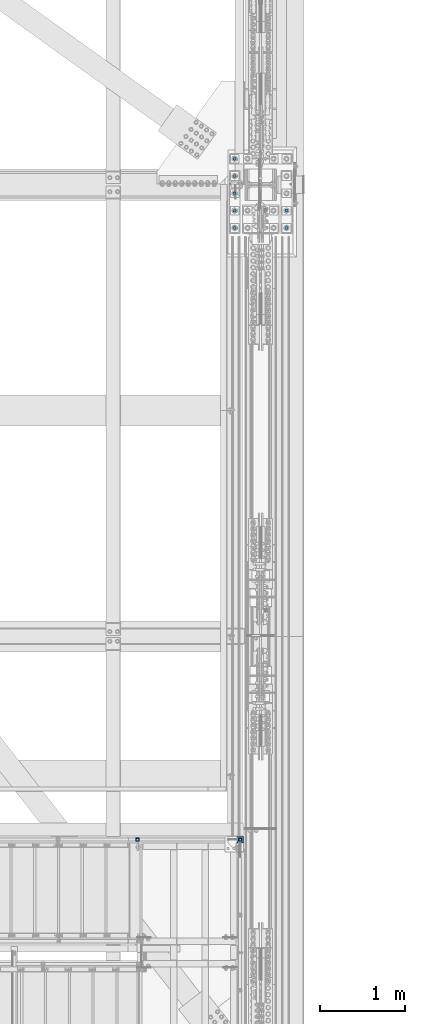
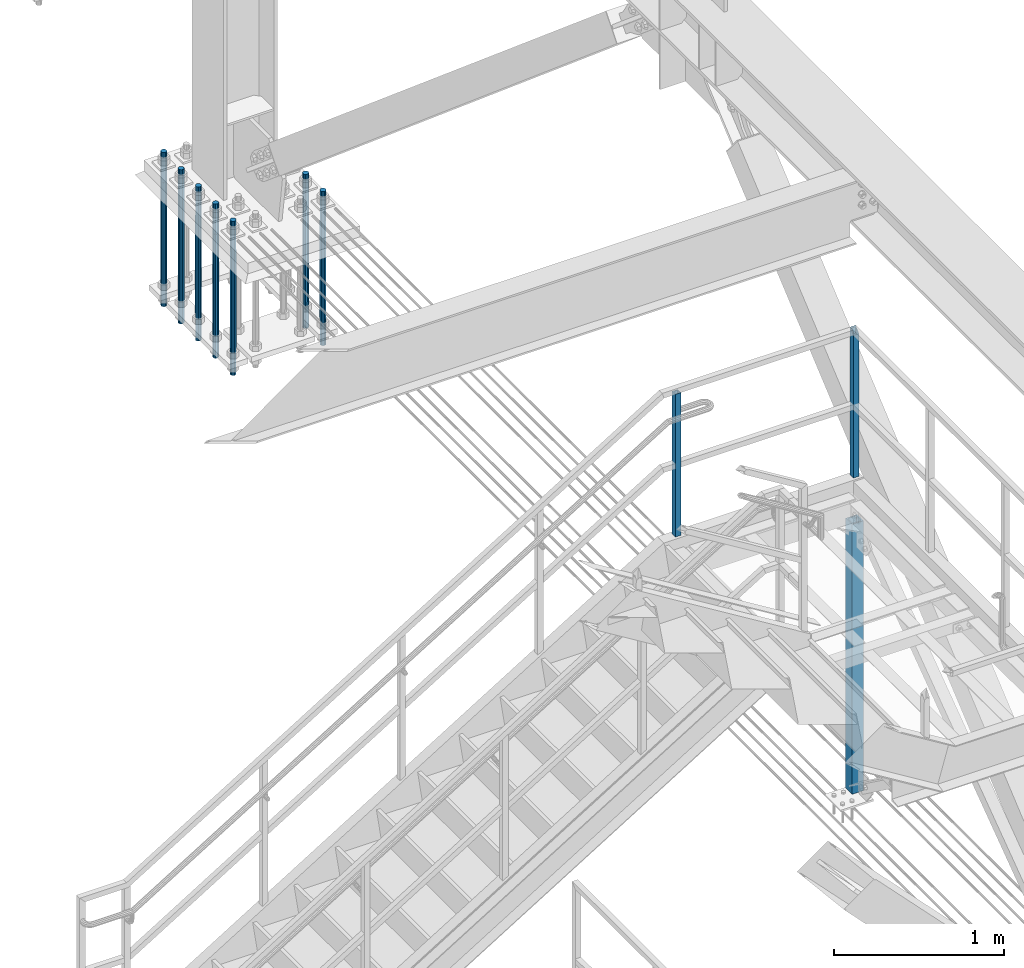
# One storey, part 1412 of 3843: 10 columns, 4 elements without a shape of their own.
"""IFC2X3 building model written with IfcOpenShell, lengths in millimetres."""

from ifc_helpers import new_model, si_unit, frame, origin_with_axes, place, context, subcontext, project, spatial, faceted_brep, material, type_object, element, aggregate, save


model = new_model("IFC2X3")

# Units and contexts
model_context = context("Model", 3, precision=1e-05, world=origin_with_axes())
body_context = subcontext(model_context, "Body", "Model", "MODEL_VIEW")
ifc_project = project(units=[si_unit("LENGTHUNIT", "METRE", prefix="MILLI"), si_unit("AREAUNIT", "SQUARE_METRE"), si_unit("VOLUMEUNIT", "CUBIC_METRE"), si_unit("MASSUNIT", "GRAM", prefix="KILO"), si_unit("TIMEUNIT", "SECOND"), si_unit("PLANEANGLEUNIT", "RADIAN"), si_unit("SOLIDANGLEUNIT", "STERADIAN"), si_unit("THERMODYNAMICTEMPERATUREUNIT", "DEGREE_CELSIUS"), si_unit("LUMINOUSINTENSITYUNIT", "LUMEN")], contexts=[model_context])

# Site, building, storey
site_placement = place(None, origin_with_axes())
site = spatial("IfcSite", under=ifc_project, at=site_placement, CompositionType="ELEMENT")
building_placement = place(site_placement, origin_with_axes())
building = spatial("IfcBuilding", under=site, at=building_placement, Name="Undefined", CompositionType="ELEMENT")
storey_placement = place(building_placement, origin_with_axes())
storey = spatial("IfcBuildingStorey", under=building, at=storey_placement, Name="Undefined", CompositionType="ELEMENT", Elevation=0.0)

# Assembly, column
assembly_1_placement = place(storey_placement, origin_with_axes())
assembly_1 = element("IfcElementAssembly", 1, at=assembly_1_placement, inside=storey, Name="RAIL", AssemblyPlace="NOTDEFINED", PredefinedType="RIGID_FRAME")
ifc_material_1 = material()
column_type_1 = type_object("IfcColumnType", Name="HSS1-1/2X1-1/2X1/4", PredefinedType="NOTDEFINED")
column_1_placement = place(assembly_1_placement, frame((84200.9999999997, 17919.7, 32715.1999999846), z_axis=(-1.0, 0.0, 0.0), x_axis=(0.0, 0.0, 1.0)))
column_1 = element("IfcColumn", 2, at=column_1_placement, type_object=column_type_1, material=ifc_material_1, Name="POST", ObjectType="HSS1-1/2X1-1/2X1/4", context=body_context, shape_type="Brep", body=[
    faceted_brep([(1047.75000076629, -19.0499992350015, 19.0499992349942), (1047.75000076629, 19.0499992350015, 19.0499992349942), (25.4000000135893, 19.0499992350015, 19.0499992349942), (25.4000000135893, -19.0499992350015, 19.0499992349942), (1047.750000765, -19.0499992350015, -19.0499992350015), (25.4000000135893, -19.0499992350015, -19.0499992349942), (1047.750000765, 19.0499992350015, -19.0499992350015), (25.4000000135893, 19.0499992350015, -19.0499992349942), (1047.75000076497, -12.6999993300014, 12.6999993299978), (1047.75000076497, 12.6999993300014, 12.6999993299978), (1047.75000076497, 12.6999993300014, -12.6999993299978), (1047.75000076497, -12.6999993300014, -12.6999993299978), (25.4000000135893, -12.6999993300014, 12.6999993299978), (25.4000000135893, 12.6999993300014, 12.6999993299978), (25.4000000135893, 12.6999993300014, -12.6999993299978), (25.4000000135893, -12.6999993300014, -12.6999993299978)], [[[0, 1, 2, 3]], [[4, 0, 3, 5]], [[6, 4, 5, 7]], [[1, 6, 7, 2]], [[0, 4, 6, 1], [8, 9, 10, 11]], [[9, 8, 12, 13]], [[10, 9, 13, 14]], [[11, 10, 14, 15]], [[8, 11, 15, 12]], [[7, 5, 3, 2], [14, 13, 12, 15]]]),
])
aggregate(assembly_1, [column_1])

assembly_2_placement = place(storey_placement, origin_with_axes())
assembly_2 = element("IfcElementAssembly", 3, at=assembly_2_placement, inside=storey, Name="RAIL", AssemblyPlace="NOTDEFINED", PredefinedType="RIGID_FRAME")
column_2_placement = place(assembly_2_placement, frame((85407.4999999662, 17919.7, 32740.599999999), z_axis=(-1.0, 0.0, 0.0), x_axis=(0.0, 0.0, 1.0)))
column_2 = element("IfcColumn", 4, at=column_2_placement, type_object=column_type_1, material=ifc_material_1, Name="POST", ObjectType="HSS1-1/2X1-1/2X1/4", context=body_context, shape_type="Brep", body=[
    faceted_brep([(0.0, 12.6999993299978, -12.6999993300014), (0.0, -12.6999993299978, -12.6999993300014), (1028.70000067009, -12.6999993300014, -12.6999993299978), (1054.10000067001, 12.6999993300014, -12.6999993299978), (0.0, -12.6999993299978, 12.6999993300014), (1028.70000067002, -12.6999993299978, 12.6999993299978), (0.0, 12.6999993299978, 12.6999993300014), (1054.10000067129, 12.6999993300014, 12.6999993299978), (0.0, 19.0500000000029, -19.0499999999993), (0.0, 19.0499992350015, 19.0499992350015), (1060.44999923509, 19.0499992350015, 19.0499992349942), (1060.44999923502, 19.0499992350015, -19.0499992350015), (0.0, -19.0499992350015, 19.0499992350015), (1022.35000076501, -19.0499992350015, 19.0499992350015), (0.0, -19.0499992350015, -19.0499992350015), (1022.35000076501, -19.0499992350015, -19.0499992350015)], [[[0, 1, 2, 3]], [[1, 4, 5, 2]], [[4, 6, 7, 5]], [[6, 0, 3, 7]], [[8, 9, 10, 11]], [[9, 12, 13, 10]], [[12, 14, 15, 13]], [[14, 8, 11, 15]], [[13, 15, 11, 10], [5, 7, 3, 2]], [[14, 12, 9, 8], [6, 4, 1, 0]]]),
])
aggregate(assembly_2, [column_2])

assembly_3_placement = place(storey_placement, origin_with_axes())
assembly_3 = element("IfcElementAssembly", 5, at=assembly_3_placement, inside=storey, Name="POST", AssemblyPlace="NOTDEFINED", PredefinedType="RIGID_FRAME")
ifc_material_2 = material()
column_type_2 = type_object("IfcColumnType", Name="HSS3X3X3/8", PredefinedType="NOTDEFINED")
column_3_placement = place(assembly_3_placement, frame((85407.5000000298, 17919.6999998921, 30480.0000000001), z_axis=(-1.0, 0.0, 0.0), x_axis=(0.0, 0.0, 1.0)))
column_3 = element("IfcColumn", 6, at=column_3_placement, type_object=column_type_2, material=ifc_material_2, Name="POST", ObjectType="HSS3X3X3/8", context=body_context, shape_type="Brep", body=[
    faceted_brep([(12.7000000000007, 28.5749999999971, -28.5749999999971), (12.7000000000007, -28.5749999999971, -28.5749999999971), (1946.27499999952, -28.5750000000007, -28.5749999999971), (1946.27499999952, 28.5750000000007, -28.5749999999971), (12.7000000000007, -28.5749999999971, 28.5749999999971), (1946.27499999952, -28.5750000000007, 28.5749999999971), (12.7000000000007, 28.5749999999971, 28.5749999999971), (1946.27499999952, 28.5750000000007, 28.5749999999971), (12.7000000000007, 38.1000000000058, -38.0999999999985), (12.7000000000007, 38.1000000000058, 38.0999999999985), (1946.27499999952, 38.0999999999985, 38.1000000000058), (1946.27499999952, 38.0999999999985, -38.1000000000058), (12.7000000000007, -38.1000000000058, 38.0999999999985), (1946.27499999952, -38.0999999999985, 38.1000000000058), (12.7000000000007, -38.1000000000058, -38.0999999999985), (1946.27499999952, -38.0999999999985, -38.1000000000058)], [[[0, 1, 2, 3]], [[1, 4, 5, 2]], [[4, 6, 7, 5]], [[6, 0, 3, 7]], [[8, 9, 10, 11]], [[9, 12, 13, 10]], [[12, 14, 15, 13]], [[14, 8, 11, 15]], [[13, 15, 11, 10], [5, 7, 3, 2]], [[14, 12, 9, 8], [6, 4, 1, 0]]]),
])
aggregate(assembly_3, [column_3])

# Assembly, columns
assembly_4_placement = place(storey_placement, origin_with_axes())
assembly_4 = element("IfcElementAssembly", 7, at=assembly_4_placement, inside=storey, Name="TEMPLATE", AssemblyPlace="NOTDEFINED", PredefinedType="RIGID_FRAME")
ifc_material_3 = material(Name="Undefined/F1554-GR.55")
column_type_3 = type_object("IfcColumnType", PredefinedType="NOTDEFINED")
column_4_placement = place(assembly_4_placement, frame((85953.6, 25107.9, 30022.8), z_axis=(1.0, 0.0, 0.0), x_axis=(0.0, 0.0, -1.0)))
column_4 = element("IfcColumn", 8, at=column_4_placement, type_object=column_type_3, material=ifc_material_3, Name="ANCHOR_ROD", context=body_context, shape_type="Brep", body=[
    faceted_brep([(-215.899999999998, -16.0214699700118, 9.25), (-215.899999999998, -9.25, 16.0214699700155), (-215.899999999998, 0.0, 18.5), (-215.899999999998, 9.25, 16.0214699700155), (-215.899999999998, 16.0214699700118, 9.25), (-215.899999999998, 18.5, 0.0), (-215.899999999998, 16.0214699700118, -9.25), (-215.899999999998, 9.25, -16.0214699700155), (-215.899999999998, 0.0, -18.5), (-215.899999999998, -9.25, -16.0214699700155), (-215.899999999998, -16.0214699700118, -9.25), (-215.899999999998, -18.5, 0.0), (0.0, 18.5, 0.0), (0.0, 16.0214699700118, -9.25), (0.0, 9.25, -16.0214699700155), (0.0, 0.0, -18.5), (0.0, -9.25, -16.0214699700155), (0.0, -16.0214699700118, -9.25), (0.0, -18.5, 0.0), (0.0, -16.0214699700118, 9.25), (0.0, -9.25, 16.0214699700155), (0.0, 0.0, 18.5), (0.0, 9.25, 16.0214699700155), (0.0, 16.0214699700118, 9.25), (0.0, -16.4977839420972, 9.52500000000146), (0.0, -9.52500000000146, 16.4977839420972), (0.0, 0.0, 19.0499989999989), (0.0, 9.52500000000146, 16.4977839420972), (0.0, 16.4977839420972, 9.52500000000146), (0.0, 19.0500000000029, 0.0), (0.0, 16.4977839420972, -9.52500000000146), (0.0, 9.52500000000146, -16.4977839420972), (0.0, 0.0, -19.0499989999989), (0.0, -9.52500000000146, -16.4977839420972), (0.0, -16.4977839420972, -9.52500000000146), (0.0, -19.0500000000029, 0.0), (698.5, -19.0499999999993, 0.0), (698.5, -16.4977839420935, 9.52499999999418), (698.5, -9.52500000000146, 16.4977839420899), (698.5, 0.0, 19.0500000000029), (698.5, 9.52500000000146, 16.4977839420899), (698.5, 16.4977839420935, 9.52499999999418), (698.5, 19.0499999999993, 0.0), (698.5, 16.4977839420935, -9.52499999999418), (698.5, 9.52500000000146, -16.4977839420899), (698.5, 0.0, -19.0500000000029), (698.5, -9.52500000000146, -16.4977839420899), (698.5, -16.4977839420935, -9.52499999999418), (698.5, -9.25, 16.0214699700155), (698.5, 0.0, 18.5), (698.5, 9.25, 16.0214699700155), (698.5, 16.0214699700118, 9.25), (698.5, 18.5, 0.0), (698.5, 16.0214699700118, -9.25), (698.5, 9.25, -16.0214699700155), (698.5, 0.0, -18.5), (698.5, -9.25, -16.0214699700155), (698.5, -16.0214699700118, -9.25), (698.5, -18.5, 0.0), (698.5, -16.0214699700118, 9.25), (889.0, -9.25, -16.0214699700155), (889.0, 0.0, -18.5), (889.0, 9.25, -16.0214699700155), (889.0, 16.0214699700118, -9.25), (889.0, 18.5, 0.0), (889.0, 16.0214699700118, 9.25), (889.0, 9.25, 16.0214699700155), (889.0, 0.0, 18.5), (889.0, -9.25, 16.0214699700155), (889.0, -16.0214699700118, 9.25), (889.0, -18.5, 0.0), (889.0, -16.0214699700118, -9.25)], [[[0, 1, 2, 3, 4, 5, 6, 7, 8, 9, 10, 11]], [[6, 5, 12, 13]], [[7, 6, 13, 14]], [[8, 7, 14, 15]], [[9, 8, 15, 16]], [[10, 9, 16, 17]], [[11, 10, 17, 18]], [[0, 11, 18, 19]], [[1, 0, 19, 20]], [[2, 1, 20, 21]], [[3, 2, 21, 22]], [[4, 3, 22, 23]], [[5, 4, 23, 12]], [[24, 25, 26, 27, 28, 29, 30, 31, 32, 33, 34, 35], [22, 21, 20, 19, 18, 17, 16, 15, 14, 13, 12, 23]], [[24, 35, 36, 37]], [[25, 24, 37, 38]], [[26, 25, 38, 39]], [[27, 26, 39, 40]], [[28, 27, 40, 41]], [[29, 28, 41, 42]], [[30, 29, 42, 43]], [[31, 30, 43, 44]], [[32, 31, 44, 45]], [[33, 32, 45, 46]], [[34, 33, 46, 47]], [[35, 34, 47, 36]], [[46, 45, 44, 43, 42, 41, 40, 39, 38, 37, 36, 47], [48, 49, 50, 51, 52, 53, 54, 55, 56, 57, 58, 59]], [[60, 61, 62, 63, 64, 65, 66, 67, 68, 69, 70, 71]], [[68, 67, 49, 48]], [[69, 68, 48, 59]], [[70, 69, 59, 58]], [[71, 70, 58, 57]], [[60, 71, 57, 56]], [[61, 60, 56, 55]], [[62, 61, 55, 54]], [[63, 62, 54, 53]], [[64, 63, 53, 52]], [[65, 64, 52, 51]], [[66, 65, 51, 50]], [[67, 66, 50, 49]]]),
])
column_5_placement = place(assembly_4_placement, frame((85953.6, 25311.1, 30022.8), z_axis=(1.0, 0.0, 0.0), x_axis=(0.0, 0.0, -1.0)))
column_5 = element("IfcColumn", 9, at=column_5_placement, type_object=column_type_3, material=ifc_material_3, Name="ANCHOR_ROD", context=body_context, shape_type="Brep", body=[
    faceted_brep([(-215.899999999998, -16.0214699700118, 9.25), (-215.899999999998, -9.25, 16.0214699700155), (-215.899999999998, 0.0, 18.5), (-215.899999999998, 9.25, 16.0214699700155), (-215.899999999998, 16.0214699700118, 9.25), (-215.899999999998, 18.5, 0.0), (-215.899999999998, 16.0214699700118, -9.25), (-215.899999999998, 9.25, -16.0214699700155), (-215.899999999998, 0.0, -18.5), (-215.899999999998, -9.25, -16.0214699700155), (-215.899999999998, -16.0214699700118, -9.25), (-215.899999999998, -18.5, 0.0), (0.0, 18.5, 0.0), (0.0, 16.0214699700118, -9.25), (0.0, 9.25, -16.0214699700155), (0.0, 0.0, -18.5), (0.0, -9.25, -16.0214699700155), (0.0, -16.0214699700118, -9.25), (0.0, -18.5, 0.0), (0.0, -16.0214699700118, 9.25), (0.0, -9.25, 16.0214699700155), (0.0, 0.0, 18.5), (0.0, 9.25, 16.0214699700155), (0.0, 16.0214699700118, 9.25), (0.0, -16.4977839420972, 9.52500000000146), (0.0, -9.52500000000146, 16.4977839420972), (0.0, 0.0, 19.0499989999989), (0.0, 9.52500000000146, 16.4977839420972), (0.0, 16.4977839420972, 9.52500000000146), (0.0, 19.0500000000029, 0.0), (0.0, 16.4977839420972, -9.52500000000146), (0.0, 9.52500000000146, -16.4977839420972), (0.0, 0.0, -19.0499989999989), (0.0, -9.52500000000146, -16.4977839420972), (0.0, -16.4977839420972, -9.52500000000146), (0.0, -19.0500000000029, 0.0), (698.5, -19.0499999999993, 0.0), (698.5, -16.4977839420935, 9.52499999999418), (698.5, -9.52500000000146, 16.4977839420899), (698.5, 0.0, 19.0500000000029), (698.5, 9.52500000000146, 16.4977839420899), (698.5, 16.4977839420935, 9.52499999999418), (698.5, 19.0499999999993, 0.0), (698.5, 16.4977839420935, -9.52499999999418), (698.5, 9.52500000000146, -16.4977839420899), (698.5, 0.0, -19.0500000000029), (698.5, -9.52500000000146, -16.4977839420899), (698.5, -16.4977839420935, -9.52499999999418), (698.5, -9.25, 16.0214699700155), (698.5, 0.0, 18.5), (698.5, 9.25, 16.0214699700155), (698.5, 16.0214699700118, 9.25), (698.5, 18.5, 0.0), (698.5, 16.0214699700118, -9.25), (698.5, 9.25, -16.0214699700155), (698.5, 0.0, -18.5), (698.5, -9.25, -16.0214699700155), (698.5, -16.0214699700118, -9.25), (698.5, -18.5, 0.0), (698.5, -16.0214699700118, 9.25), (889.0, -9.25, -16.0214699700155), (889.0, 0.0, -18.5), (889.0, 9.25, -16.0214699700155), (889.0, 16.0214699700118, -9.25), (889.0, 18.5, 0.0), (889.0, 16.0214699700118, 9.25), (889.0, 9.25, 16.0214699700155), (889.0, 0.0, 18.5), (889.0, -9.25, 16.0214699700155), (889.0, -16.0214699700118, 9.25), (889.0, -18.5, 0.0), (889.0, -16.0214699700118, -9.25)], [[[0, 1, 2, 3, 4, 5, 6, 7, 8, 9, 10, 11]], [[6, 5, 12, 13]], [[7, 6, 13, 14]], [[8, 7, 14, 15]], [[9, 8, 15, 16]], [[10, 9, 16, 17]], [[11, 10, 17, 18]], [[0, 11, 18, 19]], [[1, 0, 19, 20]], [[2, 1, 20, 21]], [[3, 2, 21, 22]], [[4, 3, 22, 23]], [[5, 4, 23, 12]], [[24, 25, 26, 27, 28, 29, 30, 31, 32, 33, 34, 35], [22, 21, 20, 19, 18, 17, 16, 15, 14, 13, 12, 23]], [[24, 35, 36, 37]], [[25, 24, 37, 38]], [[26, 25, 38, 39]], [[27, 26, 39, 40]], [[28, 27, 40, 41]], [[29, 28, 41, 42]], [[30, 29, 42, 43]], [[31, 30, 43, 44]], [[32, 31, 44, 45]], [[33, 32, 45, 46]], [[34, 33, 46, 47]], [[35, 34, 47, 36]], [[46, 45, 44, 43, 42, 41, 40, 39, 38, 37, 36, 47], [48, 49, 50, 51, 52, 53, 54, 55, 56, 57, 58, 59]], [[60, 61, 62, 63, 64, 65, 66, 67, 68, 69, 70, 71]], [[68, 67, 49, 48]], [[69, 68, 48, 59]], [[70, 69, 59, 58]], [[71, 70, 58, 57]], [[60, 71, 57, 56]], [[61, 60, 56, 55]], [[62, 61, 55, 54]], [[63, 62, 54, 53]], [[64, 63, 53, 52]], [[65, 64, 52, 51]], [[66, 65, 51, 50]], [[67, 66, 50, 49]]]),
])
column_6_placement = place(assembly_4_placement, frame((85344.0, 25107.9, 30022.8), z_axis=(1.0, 0.0, 0.0), x_axis=(0.0, 0.0, -1.0)))
column_6 = element("IfcColumn", 10, at=column_6_placement, type_object=column_type_3, material=ifc_material_3, Name="ANCHOR_ROD", context=body_context, shape_type="Brep", body=[
    faceted_brep([(-215.899999999998, -16.0214699700118, 9.25), (-215.899999999998, -9.25, 16.0214699700155), (-215.899999999998, 0.0, 18.5), (-215.899999999998, 9.25, 16.0214699700155), (-215.899999999998, 16.0214699700118, 9.25), (-215.899999999998, 18.5, 0.0), (-215.899999999998, 16.0214699700118, -9.25), (-215.899999999998, 9.25, -16.0214699700155), (-215.899999999998, 0.0, -18.5), (-215.899999999998, -9.25, -16.0214699700155), (-215.899999999998, -16.0214699700118, -9.25), (-215.899999999998, -18.5, 0.0), (0.0, 18.5, 0.0), (0.0, 16.0214699700118, -9.25), (0.0, 9.25, -16.0214699700155), (0.0, 0.0, -18.5), (0.0, -9.25, -16.0214699700155), (0.0, -16.0214699700118, -9.25), (0.0, -18.5, 0.0), (0.0, -16.0214699700118, 9.25), (0.0, -9.25, 16.0214699700155), (0.0, 0.0, 18.5), (0.0, 9.25, 16.0214699700155), (0.0, 16.0214699700118, 9.25), (0.0, -16.4977839420972, 9.52500000000146), (0.0, -9.52500000000146, 16.4977839420972), (0.0, 0.0, 19.0499989999989), (0.0, 9.52500000000146, 16.4977839420972), (0.0, 16.4977839420972, 9.52500000000146), (0.0, 19.0500000000029, 0.0), (0.0, 16.4977839420972, -9.52500000000146), (0.0, 9.52500000000146, -16.4977839420972), (0.0, 0.0, -19.0499989999989), (0.0, -9.52500000000146, -16.4977839420972), (0.0, -16.4977839420972, -9.52500000000146), (0.0, -19.0500000000029, 0.0), (698.5, -19.0499999999993, 0.0), (698.5, -16.4977839420935, 9.52499999999418), (698.5, -9.52500000000146, 16.4977839420899), (698.5, 0.0, 19.0500000000029), (698.5, 9.52500000000146, 16.4977839420899), (698.5, 16.4977839420935, 9.52499999999418), (698.5, 19.0499999999993, 0.0), (698.5, 16.4977839420935, -9.52499999999418), (698.5, 9.52500000000146, -16.4977839420899), (698.5, 0.0, -19.0500000000029), (698.5, -9.52500000000146, -16.4977839420899), (698.5, -16.4977839420935, -9.52499999999418), (698.5, -9.25, 16.0214699700155), (698.5, 0.0, 18.5), (698.5, 9.25, 16.0214699700155), (698.5, 16.0214699700118, 9.25), (698.5, 18.5, 0.0), (698.5, 16.0214699700118, -9.25), (698.5, 9.25, -16.0214699700155), (698.5, 0.0, -18.5), (698.5, -9.25, -16.0214699700155), (698.5, -16.0214699700118, -9.25), (698.5, -18.5, 0.0), (698.5, -16.0214699700118, 9.25), (889.0, -9.25, -16.0214699700155), (889.0, 0.0, -18.5), (889.0, 9.25, -16.0214699700155), (889.0, 16.0214699700118, -9.25), (889.0, 18.5, 0.0), (889.0, 16.0214699700118, 9.25), (889.0, 9.25, 16.0214699700155), (889.0, 0.0, 18.5), (889.0, -9.25, 16.0214699700155), (889.0, -16.0214699700118, 9.25), (889.0, -18.5, 0.0), (889.0, -16.0214699700118, -9.25)], [[[0, 1, 2, 3, 4, 5, 6, 7, 8, 9, 10, 11]], [[6, 5, 12, 13]], [[7, 6, 13, 14]], [[8, 7, 14, 15]], [[9, 8, 15, 16]], [[10, 9, 16, 17]], [[11, 10, 17, 18]], [[0, 11, 18, 19]], [[1, 0, 19, 20]], [[2, 1, 20, 21]], [[3, 2, 21, 22]], [[4, 3, 22, 23]], [[5, 4, 23, 12]], [[24, 25, 26, 27, 28, 29, 30, 31, 32, 33, 34, 35], [22, 21, 20, 19, 18, 17, 16, 15, 14, 13, 12, 23]], [[24, 35, 36, 37]], [[25, 24, 37, 38]], [[26, 25, 38, 39]], [[27, 26, 39, 40]], [[28, 27, 40, 41]], [[29, 28, 41, 42]], [[30, 29, 42, 43]], [[31, 30, 43, 44]], [[32, 31, 44, 45]], [[33, 32, 45, 46]], [[34, 33, 46, 47]], [[35, 34, 47, 36]], [[46, 45, 44, 43, 42, 41, 40, 39, 38, 37, 36, 47], [48, 49, 50, 51, 52, 53, 54, 55, 56, 57, 58, 59]], [[60, 61, 62, 63, 64, 65, 66, 67, 68, 69, 70, 71]], [[68, 67, 49, 48]], [[69, 68, 48, 59]], [[70, 69, 59, 58]], [[71, 70, 58, 57]], [[60, 71, 57, 56]], [[61, 60, 56, 55]], [[62, 61, 55, 54]], [[63, 62, 54, 53]], [[64, 63, 53, 52]], [[65, 64, 52, 51]], [[66, 65, 51, 50]], [[67, 66, 50, 49]]]),
])
column_7_placement = place(assembly_4_placement, frame((85344.0, 25311.1, 30022.8), z_axis=(1.0, 0.0, 0.0), x_axis=(0.0, 0.0, -1.0)))
column_7 = element("IfcColumn", 11, at=column_7_placement, type_object=column_type_3, material=ifc_material_3, Name="ANCHOR_ROD", context=body_context, shape_type="Brep", body=[
    faceted_brep([(-215.899999999998, -16.0214699700118, 9.25), (-215.899999999998, -9.25, 16.0214699700155), (-215.899999999998, 0.0, 18.5), (-215.899999999998, 9.25, 16.0214699700155), (-215.899999999998, 16.0214699700118, 9.25), (-215.899999999998, 18.5, 0.0), (-215.899999999998, 16.0214699700118, -9.25), (-215.899999999998, 9.25, -16.0214699700155), (-215.899999999998, 0.0, -18.5), (-215.899999999998, -9.25, -16.0214699700155), (-215.899999999998, -16.0214699700118, -9.25), (-215.899999999998, -18.5, 0.0), (0.0, 18.5, 0.0), (0.0, 16.0214699700118, -9.25), (0.0, 9.25, -16.0214699700155), (0.0, 0.0, -18.5), (0.0, -9.25, -16.0214699700155), (0.0, -16.0214699700118, -9.25), (0.0, -18.5, 0.0), (0.0, -16.0214699700118, 9.25), (0.0, -9.25, 16.0214699700155), (0.0, 0.0, 18.5), (0.0, 9.25, 16.0214699700155), (0.0, 16.0214699700118, 9.25), (0.0, -16.4977839420972, 9.52500000000146), (0.0, -9.52500000000146, 16.4977839420972), (0.0, 0.0, 19.0499989999989), (0.0, 9.52500000000146, 16.4977839420972), (0.0, 16.4977839420972, 9.52500000000146), (0.0, 19.0500000000029, 0.0), (0.0, 16.4977839420972, -9.52500000000146), (0.0, 9.52500000000146, -16.4977839420972), (0.0, 0.0, -19.0499989999989), (0.0, -9.52500000000146, -16.4977839420972), (0.0, -16.4977839420972, -9.52500000000146), (0.0, -19.0500000000029, 0.0), (698.5, -19.0499999999993, 0.0), (698.5, -16.4977839420935, 9.52499999999418), (698.5, -9.52500000000146, 16.4977839420899), (698.5, 0.0, 19.0500000000029), (698.5, 9.52500000000146, 16.4977839420899), (698.5, 16.4977839420935, 9.52499999999418), (698.5, 19.0499999999993, 0.0), (698.5, 16.4977839420935, -9.52499999999418), (698.5, 9.52500000000146, -16.4977839420899), (698.5, 0.0, -19.0500000000029), (698.5, -9.52500000000146, -16.4977839420899), (698.5, -16.4977839420935, -9.52499999999418), (698.5, -9.25, 16.0214699700155), (698.5, 0.0, 18.5), (698.5, 9.25, 16.0214699700155), (698.5, 16.0214699700118, 9.25), (698.5, 18.5, 0.0), (698.5, 16.0214699700118, -9.25), (698.5, 9.25, -16.0214699700155), (698.5, 0.0, -18.5), (698.5, -9.25, -16.0214699700155), (698.5, -16.0214699700118, -9.25), (698.5, -18.5, 0.0), (698.5, -16.0214699700118, 9.25), (889.0, -9.25, -16.0214699700155), (889.0, 0.0, -18.5), (889.0, 9.25, -16.0214699700155), (889.0, 16.0214699700118, -9.25), (889.0, 18.5, 0.0), (889.0, 16.0214699700118, 9.25), (889.0, 9.25, 16.0214699700155), (889.0, 0.0, 18.5), (889.0, -9.25, 16.0214699700155), (889.0, -16.0214699700118, 9.25), (889.0, -18.5, 0.0), (889.0, -16.0214699700118, -9.25)], [[[0, 1, 2, 3, 4, 5, 6, 7, 8, 9, 10, 11]], [[6, 5, 12, 13]], [[7, 6, 13, 14]], [[8, 7, 14, 15]], [[9, 8, 15, 16]], [[10, 9, 16, 17]], [[11, 10, 17, 18]], [[0, 11, 18, 19]], [[1, 0, 19, 20]], [[2, 1, 20, 21]], [[3, 2, 21, 22]], [[4, 3, 22, 23]], [[5, 4, 23, 12]], [[24, 25, 26, 27, 28, 29, 30, 31, 32, 33, 34, 35], [22, 21, 20, 19, 18, 17, 16, 15, 14, 13, 12, 23]], [[24, 35, 36, 37]], [[25, 24, 37, 38]], [[26, 25, 38, 39]], [[27, 26, 39, 40]], [[28, 27, 40, 41]], [[29, 28, 41, 42]], [[30, 29, 42, 43]], [[31, 30, 43, 44]], [[32, 31, 44, 45]], [[33, 32, 45, 46]], [[34, 33, 46, 47]], [[35, 34, 47, 36]], [[46, 45, 44, 43, 42, 41, 40, 39, 38, 37, 36, 47], [48, 49, 50, 51, 52, 53, 54, 55, 56, 57, 58, 59]], [[60, 61, 62, 63, 64, 65, 66, 67, 68, 69, 70, 71]], [[68, 67, 49, 48]], [[69, 68, 48, 59]], [[70, 69, 59, 58]], [[71, 70, 58, 57]], [[60, 71, 57, 56]], [[61, 60, 56, 55]], [[62, 61, 55, 54]], [[63, 62, 54, 53]], [[64, 63, 53, 52]], [[65, 64, 52, 51]], [[66, 65, 51, 50]], [[67, 66, 50, 49]]]),
])
column_8_placement = place(assembly_4_placement, frame((85344.0, 25514.3, 30022.8), z_axis=(1.0, 0.0, 0.0), x_axis=(0.0, 0.0, -1.0)))
column_8 = element("IfcColumn", 12, at=column_8_placement, type_object=column_type_3, material=ifc_material_3, Name="ANCHOR_ROD", context=body_context, shape_type="Brep", body=[
    faceted_brep([(-215.899999999998, -16.0214699700118, 9.25), (-215.899999999998, -9.25, 16.0214699700155), (-215.899999999998, 0.0, 18.5), (-215.899999999998, 9.25, 16.0214699700155), (-215.899999999998, 16.0214699700118, 9.25), (-215.899999999998, 18.5, 0.0), (-215.899999999998, 16.0214699700118, -9.25), (-215.899999999998, 9.25, -16.0214699700155), (-215.899999999998, 0.0, -18.5), (-215.899999999998, -9.25, -16.0214699700155), (-215.899999999998, -16.0214699700118, -9.25), (-215.899999999998, -18.5, 0.0), (0.0, 18.5, 0.0), (0.0, 16.0214699700118, -9.25), (0.0, 9.25, -16.0214699700155), (0.0, 0.0, -18.5), (0.0, -9.25, -16.0214699700155), (0.0, -16.0214699700118, -9.25), (0.0, -18.5, 0.0), (0.0, -16.0214699700118, 9.25), (0.0, -9.25, 16.0214699700155), (0.0, 0.0, 18.5), (0.0, 9.25, 16.0214699700155), (0.0, 16.0214699700118, 9.25), (0.0, -16.4977839420972, 9.52500000000146), (0.0, -9.52500000000146, 16.4977839420972), (0.0, 0.0, 19.0499989999989), (0.0, 9.52500000000146, 16.4977839420972), (0.0, 16.4977839420972, 9.52500000000146), (0.0, 19.0500000000029, 0.0), (0.0, 16.4977839420972, -9.52500000000146), (0.0, 9.52500000000146, -16.4977839420972), (0.0, 0.0, -19.0499989999989), (0.0, -9.52500000000146, -16.4977839420972), (0.0, -16.4977839420972, -9.52500000000146), (0.0, -19.0500000000029, 0.0), (698.5, -19.0499999999993, 0.0), (698.5, -16.4977839420935, 9.52499999999418), (698.5, -9.52500000000146, 16.4977839420899), (698.5, 0.0, 19.0500000000029), (698.5, 9.52500000000146, 16.4977839420899), (698.5, 16.4977839420935, 9.52499999999418), (698.5, 19.0499999999993, 0.0), (698.5, 16.4977839420935, -9.52499999999418), (698.5, 9.52500000000146, -16.4977839420899), (698.5, 0.0, -19.0500000000029), (698.5, -9.52500000000146, -16.4977839420899), (698.5, -16.4977839420935, -9.52499999999418), (698.5, -9.25, 16.0214699700155), (698.5, 0.0, 18.5), (698.5, 9.25, 16.0214699700155), (698.5, 16.0214699700118, 9.25), (698.5, 18.5, 0.0), (698.5, 16.0214699700118, -9.25), (698.5, 9.25, -16.0214699700155), (698.5, 0.0, -18.5), (698.5, -9.25, -16.0214699700155), (698.5, -16.0214699700118, -9.25), (698.5, -18.5, 0.0), (698.5, -16.0214699700118, 9.25), (889.0, -9.25, -16.0214699700155), (889.0, 0.0, -18.5), (889.0, 9.25, -16.0214699700155), (889.0, 16.0214699700118, -9.25), (889.0, 18.5, 0.0), (889.0, 16.0214699700118, 9.25), (889.0, 9.25, 16.0214699700155), (889.0, 0.0, 18.5), (889.0, -9.25, 16.0214699700155), (889.0, -16.0214699700118, 9.25), (889.0, -18.5, 0.0), (889.0, -16.0214699700118, -9.25)], [[[0, 1, 2, 3, 4, 5, 6, 7, 8, 9, 10, 11]], [[6, 5, 12, 13]], [[7, 6, 13, 14]], [[8, 7, 14, 15]], [[9, 8, 15, 16]], [[10, 9, 16, 17]], [[11, 10, 17, 18]], [[0, 11, 18, 19]], [[1, 0, 19, 20]], [[2, 1, 20, 21]], [[3, 2, 21, 22]], [[4, 3, 22, 23]], [[5, 4, 23, 12]], [[24, 25, 26, 27, 28, 29, 30, 31, 32, 33, 34, 35], [22, 21, 20, 19, 18, 17, 16, 15, 14, 13, 12, 23]], [[24, 35, 36, 37]], [[25, 24, 37, 38]], [[26, 25, 38, 39]], [[27, 26, 39, 40]], [[28, 27, 40, 41]], [[29, 28, 41, 42]], [[30, 29, 42, 43]], [[31, 30, 43, 44]], [[32, 31, 44, 45]], [[33, 32, 45, 46]], [[34, 33, 46, 47]], [[35, 34, 47, 36]], [[46, 45, 44, 43, 42, 41, 40, 39, 38, 37, 36, 47], [48, 49, 50, 51, 52, 53, 54, 55, 56, 57, 58, 59]], [[60, 61, 62, 63, 64, 65, 66, 67, 68, 69, 70, 71]], [[68, 67, 49, 48]], [[69, 68, 48, 59]], [[70, 69, 59, 58]], [[71, 70, 58, 57]], [[60, 71, 57, 56]], [[61, 60, 56, 55]], [[62, 61, 55, 54]], [[63, 62, 54, 53]], [[64, 63, 53, 52]], [[65, 64, 52, 51]], [[66, 65, 51, 50]], [[67, 66, 50, 49]]]),
])
column_9_placement = place(assembly_4_placement, frame((85344.0, 25717.5, 30022.8), z_axis=(-1.0, 0.0, 0.0), x_axis=(0.0, 0.0, -1.0)))
column_9 = element("IfcColumn", 13, at=column_9_placement, type_object=column_type_3, material=ifc_material_3, Name="ANCHOR_ROD", context=body_context, shape_type="Brep", body=[
    faceted_brep([(-215.899999999998, -16.0214699700118, 9.25), (-215.899999999998, -9.25, 16.0214699700155), (-215.899999999998, 0.0, 18.5), (-215.899999999998, 9.25, 16.0214699700155), (-215.899999999998, 16.0214699700118, 9.25), (-215.899999999998, 18.5, 0.0), (-215.899999999998, 16.0214699700118, -9.25), (-215.899999999998, 9.25, -16.0214699700155), (-215.899999999998, 0.0, -18.5), (-215.899999999998, -9.25, -16.0214699700155), (-215.899999999998, -16.0214699700118, -9.25), (-215.899999999998, -18.5, 0.0), (0.0, 18.5, 0.0), (0.0, 16.0214699700118, -9.25), (0.0, 9.25, -16.0214699700155), (0.0, 0.0, -18.5), (0.0, -9.25, -16.0214699700155), (0.0, -16.0214699700118, -9.25), (0.0, -18.5, 0.0), (0.0, -16.0214699700118, 9.25), (0.0, -9.25, 16.0214699700155), (0.0, 0.0, 18.5), (0.0, 9.25, 16.0214699700155), (0.0, 16.0214699700118, 9.25), (0.0, -16.4977839420972, 9.52500000000146), (0.0, -9.52500000000146, 16.4977839420972), (0.0, 0.0, 19.0499989999989), (0.0, 9.52500000000146, 16.4977839420972), (0.0, 16.4977839420972, 9.52500000000146), (0.0, 19.0500000000029, 0.0), (0.0, 16.4977839420972, -9.52500000000146), (0.0, 9.52500000000146, -16.4977839420972), (0.0, 0.0, -19.0499989999989), (0.0, -9.52500000000146, -16.4977839420972), (0.0, -16.4977839420972, -9.52500000000146), (0.0, -19.0500000000029, 0.0), (698.5, -19.0499999999993, 0.0), (698.5, -16.4977839420935, 9.52499999999418), (698.5, -9.52500000000146, 16.4977839420899), (698.5, 0.0, 19.0500000000029), (698.5, 9.52500000000146, 16.4977839420899), (698.5, 16.4977839420935, 9.52499999999418), (698.5, 19.0499999999993, 0.0), (698.5, 16.4977839420935, -9.52499999999418), (698.5, 9.52500000000146, -16.4977839420899), (698.5, 0.0, -19.0500000000029), (698.5, -9.52500000000146, -16.4977839420899), (698.5, -16.4977839420935, -9.52499999999418), (698.5, -9.25, 16.0214699700155), (698.5, 0.0, 18.5), (698.5, 9.25, 16.0214699700155), (698.5, 16.0214699700118, 9.25), (698.5, 18.5, 0.0), (698.5, 16.0214699700118, -9.25), (698.5, 9.25, -16.0214699700155), (698.5, 0.0, -18.5), (698.5, -9.25, -16.0214699700155), (698.5, -16.0214699700118, -9.25), (698.5, -18.5, 0.0), (698.5, -16.0214699700118, 9.25), (889.0, -9.25, -16.0214699700155), (889.0, 0.0, -18.5), (889.0, 9.25, -16.0214699700155), (889.0, 16.0214699700118, -9.25), (889.0, 18.5, 0.0), (889.0, 16.0214699700118, 9.25), (889.0, 9.25, 16.0214699700155), (889.0, 0.0, 18.5), (889.0, -9.25, 16.0214699700155), (889.0, -16.0214699700118, 9.25), (889.0, -18.5, 0.0), (889.0, -16.0214699700118, -9.25)], [[[0, 1, 2, 3, 4, 5, 6, 7, 8, 9, 10, 11]], [[6, 5, 12, 13]], [[7, 6, 13, 14]], [[8, 7, 14, 15]], [[9, 8, 15, 16]], [[10, 9, 16, 17]], [[11, 10, 17, 18]], [[0, 11, 18, 19]], [[1, 0, 19, 20]], [[2, 1, 20, 21]], [[3, 2, 21, 22]], [[4, 3, 22, 23]], [[5, 4, 23, 12]], [[24, 25, 26, 27, 28, 29, 30, 31, 32, 33, 34, 35], [22, 21, 20, 19, 18, 17, 16, 15, 14, 13, 12, 23]], [[24, 35, 36, 37]], [[25, 24, 37, 38]], [[26, 25, 38, 39]], [[27, 26, 39, 40]], [[28, 27, 40, 41]], [[29, 28, 41, 42]], [[30, 29, 42, 43]], [[31, 30, 43, 44]], [[32, 31, 44, 45]], [[33, 32, 45, 46]], [[34, 33, 46, 47]], [[35, 34, 47, 36]], [[46, 45, 44, 43, 42, 41, 40, 39, 38, 37, 36, 47], [48, 49, 50, 51, 52, 53, 54, 55, 56, 57, 58, 59]], [[60, 61, 62, 63, 64, 65, 66, 67, 68, 69, 70, 71]], [[68, 67, 49, 48]], [[69, 68, 48, 59]], [[70, 69, 59, 58]], [[71, 70, 58, 57]], [[60, 71, 57, 56]], [[61, 60, 56, 55]], [[62, 61, 55, 54]], [[63, 62, 54, 53]], [[64, 63, 53, 52]], [[65, 64, 52, 51]], [[66, 65, 51, 50]], [[67, 66, 50, 49]]]),
])
column_10_placement = place(assembly_4_placement, frame((85344.0, 25920.7, 30022.8), z_axis=(-1.0, 0.0, 0.0), x_axis=(0.0, 0.0, -1.0)))
column_10 = element("IfcColumn", 14, at=column_10_placement, type_object=column_type_3, material=ifc_material_3, Name="ANCHOR_ROD", context=body_context, shape_type="Brep", body=[
    faceted_brep([(-215.899999999998, -16.0214699700118, 9.25), (-215.899999999998, -9.25, 16.0214699700155), (-215.899999999998, 0.0, 18.5), (-215.899999999998, 9.25, 16.0214699700155), (-215.899999999998, 16.0214699700118, 9.25), (-215.899999999998, 18.5, 0.0), (-215.899999999998, 16.0214699700118, -9.25), (-215.899999999998, 9.25, -16.0214699700155), (-215.899999999998, 0.0, -18.5), (-215.899999999998, -9.25, -16.0214699700155), (-215.899999999998, -16.0214699700118, -9.25), (-215.899999999998, -18.5, 0.0), (0.0, 18.5, 0.0), (0.0, 16.0214699700118, -9.25), (0.0, 9.25, -16.0214699700155), (0.0, 0.0, -18.5), (0.0, -9.25, -16.0214699700155), (0.0, -16.0214699700118, -9.25), (0.0, -18.5, 0.0), (0.0, -16.0214699700118, 9.25), (0.0, -9.25, 16.0214699700155), (0.0, 0.0, 18.5), (0.0, 9.25, 16.0214699700155), (0.0, 16.0214699700118, 9.25), (0.0, -16.4977839420972, 9.52500000000146), (0.0, -9.52500000000146, 16.4977839420972), (0.0, 0.0, 19.0499989999989), (0.0, 9.52500000000146, 16.4977839420972), (0.0, 16.4977839420972, 9.52500000000146), (0.0, 19.0500000000029, 0.0), (0.0, 16.4977839420972, -9.52500000000146), (0.0, 9.52500000000146, -16.4977839420972), (0.0, 0.0, -19.0499989999989), (0.0, -9.52500000000146, -16.4977839420972), (0.0, -16.4977839420972, -9.52500000000146), (0.0, -19.0500000000029, 0.0), (698.5, -19.0499999999993, 0.0), (698.5, -16.4977839420935, 9.52499999999418), (698.5, -9.52500000000146, 16.4977839420899), (698.5, 0.0, 19.0500000000029), (698.5, 9.52500000000146, 16.4977839420899), (698.5, 16.4977839420935, 9.52499999999418), (698.5, 19.0499999999993, 0.0), (698.5, 16.4977839420935, -9.52499999999418), (698.5, 9.52500000000146, -16.4977839420899), (698.5, 0.0, -19.0500000000029), (698.5, -9.52500000000146, -16.4977839420899), (698.5, -16.4977839420935, -9.52499999999418), (698.5, -9.25, 16.0214699700155), (698.5, 0.0, 18.5), (698.5, 9.25, 16.0214699700155), (698.5, 16.0214699700118, 9.25), (698.5, 18.5, 0.0), (698.5, 16.0214699700118, -9.25), (698.5, 9.25, -16.0214699700155), (698.5, 0.0, -18.5), (698.5, -9.25, -16.0214699700155), (698.5, -16.0214699700118, -9.25), (698.5, -18.5, 0.0), (698.5, -16.0214699700118, 9.25), (889.0, -9.25, -16.0214699700155), (889.0, 0.0, -18.5), (889.0, 9.25, -16.0214699700155), (889.0, 16.0214699700118, -9.25), (889.0, 18.5, 0.0), (889.0, 16.0214699700118, 9.25), (889.0, 9.25, 16.0214699700155), (889.0, 0.0, 18.5), (889.0, -9.25, 16.0214699700155), (889.0, -16.0214699700118, 9.25), (889.0, -18.5, 0.0), (889.0, -16.0214699700118, -9.25)], [[[0, 1, 2, 3, 4, 5, 6, 7, 8, 9, 10, 11]], [[6, 5, 12, 13]], [[7, 6, 13, 14]], [[8, 7, 14, 15]], [[9, 8, 15, 16]], [[10, 9, 16, 17]], [[11, 10, 17, 18]], [[0, 11, 18, 19]], [[1, 0, 19, 20]], [[2, 1, 20, 21]], [[3, 2, 21, 22]], [[4, 3, 22, 23]], [[5, 4, 23, 12]], [[24, 25, 26, 27, 28, 29, 30, 31, 32, 33, 34, 35], [22, 21, 20, 19, 18, 17, 16, 15, 14, 13, 12, 23]], [[24, 35, 36, 37]], [[25, 24, 37, 38]], [[26, 25, 38, 39]], [[27, 26, 39, 40]], [[28, 27, 40, 41]], [[29, 28, 41, 42]], [[30, 29, 42, 43]], [[31, 30, 43, 44]], [[32, 31, 44, 45]], [[33, 32, 45, 46]], [[34, 33, 46, 47]], [[35, 34, 47, 36]], [[46, 45, 44, 43, 42, 41, 40, 39, 38, 37, 36, 47], [48, 49, 50, 51, 52, 53, 54, 55, 56, 57, 58, 59]], [[60, 61, 62, 63, 64, 65, 66, 67, 68, 69, 70, 71]], [[68, 67, 49, 48]], [[69, 68, 48, 59]], [[70, 69, 59, 58]], [[71, 70, 58, 57]], [[60, 71, 57, 56]], [[61, 60, 56, 55]], [[62, 61, 55, 54]], [[63, 62, 54, 53]], [[64, 63, 53, 52]], [[65, 64, 52, 51]], [[66, 65, 51, 50]], [[67, 66, 50, 49]]]),
])
aggregate(assembly_4, [column_4, column_5, column_6, column_7, column_8, column_9, column_10])

save(model, "model.ifc")
